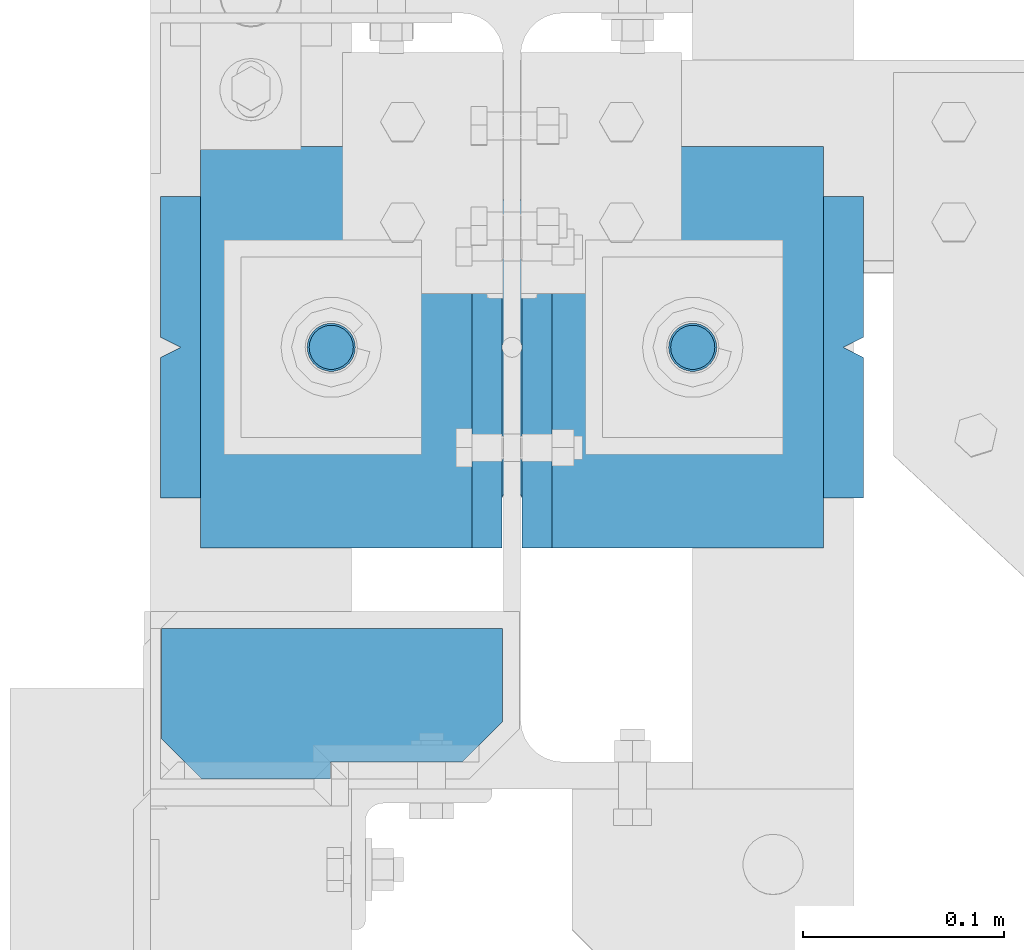
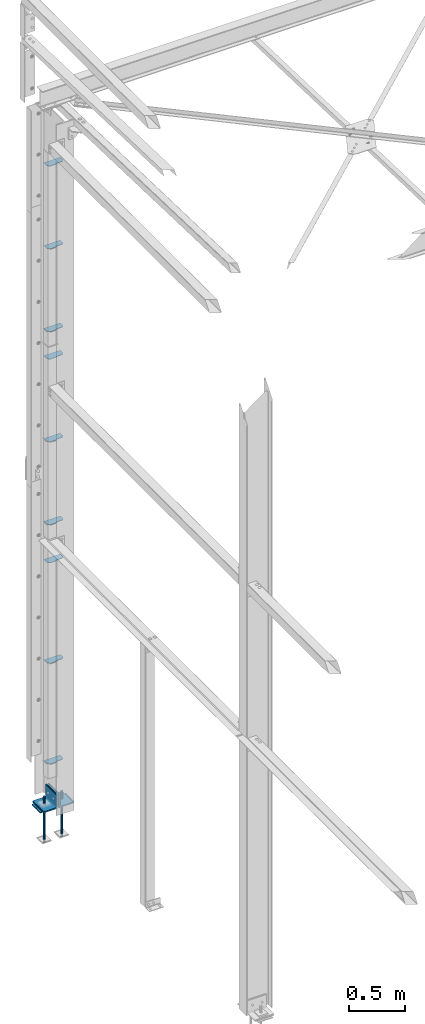
# One storey, part 79 of 496: 16 beams, 4 elements without a shape of their own.
"""IFC2X3 building model written with IfcOpenShell, lengths in millimetres."""

from ifc_helpers import new_model, si_unit, frame, origin_with_axes, origin_2d_with_axis, place, context, subcontext, project, spatial, polyline, rectangle, circle, l_section, outline, extrude, boolean, material, type_object, element, aggregate, save


model = new_model("IFC2X3")

# Units and contexts
model_context = context("Model", 3, precision=1e-05, world=origin_with_axes())
body_context = subcontext(model_context, "Body", "Model", "MODEL_VIEW")
ifc_project = project(units=[si_unit("LENGTHUNIT", "METRE", prefix="MILLI"), si_unit("AREAUNIT", "SQUARE_METRE"), si_unit("VOLUMEUNIT", "CUBIC_METRE"), si_unit("MASSUNIT", "GRAM", prefix="KILO"), si_unit("TIMEUNIT", "SECOND"), si_unit("PLANEANGLEUNIT", "RADIAN"), si_unit("SOLIDANGLEUNIT", "STERADIAN"), si_unit("THERMODYNAMICTEMPERATUREUNIT", "DEGREE_CELSIUS"), si_unit("LUMINOUSINTENSITYUNIT", "LUMEN")], contexts=[model_context])

# Site, building, storey
site_placement = place(None, origin_with_axes())
site = spatial("IfcSite", under=ifc_project, at=site_placement, CompositionType="ELEMENT")
building_placement = place(site_placement, origin_with_axes())
building = spatial("IfcBuilding", under=site, at=building_placement, Name="Undefined", CompositionType="ELEMENT")
storey_placement = place(building_placement, origin_with_axes())
storey = spatial("IfcBuildingStorey", under=building, at=storey_placement, Name="Undefined", CompositionType="ELEMENT", Elevation=0.0)

# Assembly, beams
assembly_1_placement = place(storey_placement, origin_with_axes())
assembly_1 = element("IfcElementAssembly", 1, at=assembly_1_placement, inside=storey, Name="PS24", AssemblyPlace="NOTDEFINED", PredefinedType="NOTDEFINED")
ifc_material = material(Name="Undefined/S235-E24")
beam_type_1 = type_object("IfcBeamType", Name="D24", PredefinedType="NOTDEFINED")
beam_1_placement = place(assembly_1_placement, frame((-90.0028495552906, 15109.9999996154, -100.0), z_axis=(0.0, 1.0, 0.0), x_axis=(0.0, 0.0, -1.0)))
beam_1 = element("IfcBeam", 2, at=beam_1_placement, type_object=beam_type_1, material=ifc_material, ObjectType="D24", context=body_context, shape_type="SweptSolid", body=[
    extrude(circle(Radius=12.0, at=origin_2d_with_axis()), frame((149.999995982835, 4.54747350886464e-12, 3.63797880709171e-12), z_axis=(-1.0, 0.0, 0.0), x_axis=(0.0, -1.0, 0.0)), (0.0, 0.0, 1.0), 150.0),
])
beam_2_placement = place(assembly_1_placement, frame((89.9971504447094, 15109.9999996154, -100.0), z_axis=(0.0, 1.0, 0.0), x_axis=(0.0, 0.0, -1.0)))
beam_2 = element("IfcBeam", 3, at=beam_2_placement, type_object=beam_type_1, material=ifc_material, ObjectType="D24", context=body_context, shape_type="SweptSolid", body=[
    extrude(circle(Radius=12.0, at=origin_2d_with_axis()), frame((149.999995982835, 4.54747350886464e-12, 3.63797880709171e-12), z_axis=(-1.0, 0.0, 0.0), x_axis=(0.0, -1.0, 0.0)), (0.0, 0.0, 1.0), 150.0),
])
beam_type_2 = type_object("IfcBeamType", Name="D22", PredefinedType="NOTDEFINED")
beam_3_placement = place(assembly_1_placement, frame((-90.0028495552906, 15109.9999996154, -250.0), z_axis=(0.0, 1.0, 0.0), x_axis=(0.0, 0.0, -1.0)))
beam_3 = element("IfcBeam", 4, at=beam_3_placement, type_object=beam_type_2, material=ifc_material, ObjectType="D22", context=body_context, shape_type="SweptSolid", body=[
    extrude(circle(Radius=11.0, at=origin_2d_with_axis()), frame((350.0, 0.0, 0.0), z_axis=(-1.0, 0.0, 0.0), x_axis=(0.0, -1.0, 0.0)), (0.0, 0.0, 1.0), 350.0),
])
beam_4_placement = place(assembly_1_placement, frame((89.9971504447094, 15109.9999996154, -250.0), z_axis=(0.0, 1.0, 0.0), x_axis=(0.0, 0.0, -1.0)))
beam_4 = element("IfcBeam", 5, at=beam_4_placement, type_object=beam_type_2, material=ifc_material, ObjectType="D22", context=body_context, shape_type="SweptSolid", body=[
    extrude(circle(Radius=11.0, at=origin_2d_with_axis()), frame((350.0, 0.0, 0.0), z_axis=(-1.0, 0.0, 0.0), x_axis=(0.0, -1.0, 0.0)), (0.0, 0.0, 1.0), 350.0),
])
beam_type_3 = type_object("IfcBeamType", PredefinedType="NOTDEFINED")
beam_5_placement = place(assembly_1_placement, frame((175.0, 15109.9999996154, -205.0), z_axis=(0.0, -1.0, 0.0), x_axis=(-1.0, 0.0, 0.0)))
beam_5 = element("IfcBeam", 6, at=beam_5_placement, type_object=beam_type_3, material=ifc_material, Name="PS24", context=body_context, shape_type="CSG", body=[
    boolean("DIFFERENCE", boolean("DIFFERENCE", boolean("DIFFERENCE", boolean("DIFFERENCE", extrude(rectangle(XDim=10.0, YDim=150.0, at=origin_2d_with_axis()), frame((350.0, 0.0, 0.0), z_axis=(-1.0, 0.0, 0.0), x_axis=(0.0, -1.0, 0.0)), (0.0, 0.0, 1.0), 350.0), extrude(outline(polyline([(0.0, 0.0), (11.1803398132297, 1.2732925824821e-11), (4.47213602066586, 8.94427204135718), (0.0, 0.0)])), frame((0.0, 7.5, -5.0), z_axis=(0.0, -1.0, 0.0), x_axis=(0.894427191199935, 0.0, 0.44721359509992)), (0.0, 0.0, 1.0), 15.0)), extrude(outline(polyline([(0.0, 0.0), (11.1803398132297, 1.2732925824821e-11), (4.47213602066586, 8.94427204135718), (0.0, 0.0)])), frame((180.0, 7.5, -75.0), z_axis=(0.0, -1.0, 0.0), x_axis=(-0.447213595099959, 0.0, 0.894427191199915)), (0.0, 0.0, 1.0), 15.0)), extrude(outline(polyline([(0.0, 0.0), (11.1803398132297, 1.2732925824821e-11), (6.70820379256475, 8.94427204134627), (0.0, 0.0)])), frame((340.0, 7.5, 0.0), z_axis=(0.0, -1.0, 0.0), x_axis=(0.894427191199935, 0.0, -0.44721359509992)), (0.0, 0.0, 1.0), 15.0)), extrude(outline(polyline([(0.0, 0.0), (11.1803398132297, 1.2732925824821e-11), (4.47213602066586, 8.94427204135718), (0.0, 0.0)])), frame((170.0, 7.5, 75.0), z_axis=(0.0, -1.0, 0.0), x_axis=(0.447213595099959, 0.0, -0.894427191199915)), (0.0, 0.0, 1.0), 15.0)),
])
aggregate(assembly_1, [beam_1, beam_3, beam_2, beam_4, beam_5])

assembly_2_placement = place(storey_placement, origin_with_axes())
assembly_2 = element("IfcElementAssembly", 7, at=assembly_2_placement, inside=storey, Name="POTEAU", AssemblyPlace="NOTDEFINED", PredefinedType="NOTDEFINED")
beam_type_4 = type_object("IfcBeamType", PredefinedType="NOTDEFINED")
beam_6_placement = place(assembly_2_placement, frame((-90.4999965190107, 14894.9999950373, 6035.00000055154), z_axis=(0.0, 0.0, 1.0), x_axis=(0.0, 1.0, 0.0)))
beam_6 = element("IfcBeam", 8, at=beam_6_placement, type_object=beam_type_4, material=ifc_material, context=body_context, shape_type="SweptSolid", body=[
    extrude(outline(polyline([(0.0, 0.0), (8.50000476837158, -7.37543359718984e-12), (8.50000476846641, -65.6999969482573), (28.5000047684953, -85.6999969482928), (75.0000076295182, -85.6999969483754), (75.0000076292763, 84.0000305174449), (20.0000001612298, 84.0000305175426), (1.22841738717662e-07, 64.0000305175781), (0.0, 0.0)])), frame((0.0, 0.0, -2.5), z_axis=(0.0, 0.0, 1.0), x_axis=(1.0, 0.0, 0.0)), (0.0, 0.0, 1.0), 5.0),
])
beam_7_placement = place(assembly_2_placement, frame((-90.4999965078626, 14895.0002723382, 3924.99998199652), z_axis=(0.0, 0.0, 1.0), x_axis=(0.0, 1.0, 0.0)))
beam_7 = element("IfcBeam", 9, at=beam_7_placement, type_object=beam_type_4, material=ifc_material, context=body_context, shape_type="SweptSolid", body=[
    extrude(outline(polyline([(0.0, 0.0), (8.50000476837158, -7.37543359718984e-12), (8.50000476846641, -65.6999969482573), (28.5000047684953, -85.6999969482928), (75.0000076295182, -85.6999969483754), (75.0000076292763, 84.0000305174449), (20.0000001612298, 84.0000305175426), (1.22841738717662e-07, 64.0000305175781), (0.0, 0.0)])), frame((0.0, 0.0, -2.5), z_axis=(0.0, 0.0, 1.0), x_axis=(1.0, 0.0, 0.0)), (0.0, 0.0, 1.0), 5.0),
])
beam_8_placement = place(assembly_2_placement, frame((-90.4999965136508, 14894.9999997548, 1505.00000012569), z_axis=(0.0, 0.0, 1.0), x_axis=(0.0, 1.0, 0.0)))
beam_8 = element("IfcBeam", 10, at=beam_8_placement, type_object=beam_type_4, material=ifc_material, context=body_context, shape_type="SweptSolid", body=[
    extrude(outline(polyline([(0.0, 0.0), (8.50000476837158, -7.37543359718984e-12), (8.50000476846641, -65.6999969482573), (28.5000047684953, -85.6999969482928), (75.0000076295182, -85.6999969483754), (75.0000076292763, 84.0000305174449), (20.0000001612298, 84.0000305175426), (1.22841738717662e-07, 64.0000305175781), (0.0, 0.0)])), frame((0.0, 0.0, -2.5), z_axis=(0.0, 0.0, 1.0), x_axis=(1.0, 0.0, 0.0)), (0.0, 0.0, 1.0), 5.0),
])
beam_9_placement = place(assembly_2_placement, frame((-90.4999965078027, 14894.9999980974, 2605.00000071572), z_axis=(0.0, 0.0, 1.0), x_axis=(0.0, 1.0, 0.0)))
beam_9 = element("IfcBeam", 11, at=beam_9_placement, type_object=beam_type_4, material=ifc_material, context=body_context, shape_type="SweptSolid", body=[
    extrude(outline(polyline([(0.0, 0.0), (8.50000476837158, -7.37543359718984e-12), (8.50000476846641, -65.6999969482573), (28.5000047684953, -85.6999969482928), (75.0000076295182, -85.6999969483754), (75.0000076292763, 84.0000305174449), (20.0000001612298, 84.0000305175426), (1.22841738717662e-07, 64.0000305175781), (0.0, 0.0)])), frame((0.0, 0.0, -2.5), z_axis=(0.0, 0.0, 1.0), x_axis=(1.0, 0.0, 0.0)), (0.0, 0.0, 1.0), 5.0),
])
beam_10_placement = place(assembly_2_placement, frame((-90.4999965023681, 14895.0000014121, 404.999999535647), z_axis=(0.0, 0.0, 1.0), x_axis=(0.0, 1.0, 0.0)))
beam_10 = element("IfcBeam", 12, at=beam_10_placement, type_object=beam_type_4, material=ifc_material, context=body_context, shape_type="SweptSolid", body=[
    extrude(outline(polyline([(0.0, 0.0), (8.50000476837158, -7.37543359718984e-12), (8.50000476846641, -65.6999969482573), (28.5000047684953, -85.6999969482928), (75.0000076295182, -85.6999969483754), (75.0000076292763, 84.0000305174449), (20.0000001612298, 84.0000305175426), (1.22841738717662e-07, 64.0000305175781), (0.0, 0.0)])), frame((0.0, 0.0, -2.5), z_axis=(0.0, 0.0, 1.0), x_axis=(1.0, 0.0, 0.0)), (0.0, 0.0, 1.0), 5.0),
])
beam_11_placement = place(assembly_2_placement, frame((-90.4999965131625, 14895.0000045366, 6939.99998843758), z_axis=(0.0, 0.0, 1.0), x_axis=(0.0, 1.0, 0.0)))
beam_11 = element("IfcBeam", 13, at=beam_11_placement, type_object=beam_type_4, material=ifc_material, context=body_context, shape_type="SweptSolid", body=[
    extrude(outline(polyline([(0.0, 0.0), (8.50000476837158, -7.37543359718984e-12), (8.50000476846641, -65.6999969482573), (28.5000047684953, -85.6999969482928), (75.0000076295182, -85.6999969483754), (75.0000076292763, 84.0000305174449), (20.0000001612298, 84.0000305175426), (1.22841738717662e-07, 64.0000305175781), (0.0, 0.0)])), frame((0.0, 0.0, -2.5), z_axis=(0.0, 0.0, 1.0), x_axis=(1.0, 0.0, 0.0)), (0.0, 0.0, 1.0), 5.0),
])
beam_12_placement = place(assembly_2_placement, frame((-90.4999965117919, 14894.9999207421, 5130.00000007699), z_axis=(0.0, 0.0, 1.0), x_axis=(0.0, 1.0, 0.0)))
beam_12 = element("IfcBeam", 14, at=beam_12_placement, type_object=beam_type_4, material=ifc_material, context=body_context, shape_type="SweptSolid", body=[
    extrude(outline(polyline([(0.0, 0.0), (8.50000476837158, -7.37543359718984e-12), (8.50000476846641, -65.6999969482573), (28.5000047684953, -85.6999969482928), (75.0000076295182, -85.6999969483754), (75.0000076292763, 84.0000305174449), (20.0000001612298, 84.0000305175426), (1.22841738717662e-07, 64.0000305175781), (0.0, 0.0)])), frame((0.0, 0.0, -2.5), z_axis=(0.0, 0.0, 1.0), x_axis=(1.0, 0.0, 0.0)), (0.0, 0.0, 1.0), 5.0),
])
beam_13_placement = place(assembly_2_placement, frame((-90.4999965020145, 14895.00054377, 4829.99996391821), z_axis=(0.0, 0.0, 1.0), x_axis=(0.0, 1.0, 0.0)))
beam_13 = element("IfcBeam", 15, at=beam_13_placement, type_object=beam_type_4, material=ifc_material, context=body_context, shape_type="SweptSolid", body=[
    extrude(outline(polyline([(0.0, 0.0), (8.50000476837158, -7.37543359718984e-12), (8.50000476846641, -65.6999969482573), (28.5000047684953, -85.6999969482928), (75.0000076295182, -85.6999969483754), (75.0000076292763, 84.0000305174449), (20.0000001612298, 84.0000305175426), (1.22841738717662e-07, 64.0000305175781), (0.0, 0.0)])), frame((0.0, 0.0, -2.5), z_axis=(0.0, 0.0, 1.0), x_axis=(1.0, 0.0, 0.0)), (0.0, 0.0, 1.0), 5.0),
])
beam_14_placement = place(assembly_2_placement, frame((-90.4999964966154, 14895.0000009063, 3020.00000007662), z_axis=(0.0, 0.0, 1.0), x_axis=(0.0, 1.0, 0.0)))
beam_14 = element("IfcBeam", 16, at=beam_14_placement, type_object=beam_type_4, material=ifc_material, context=body_context, shape_type="SweptSolid", body=[
    extrude(outline(polyline([(0.0, 0.0), (8.50000476837158, -7.37543359718984e-12), (8.50000476846641, -65.6999969482573), (28.5000047684953, -85.6999969482928), (75.0000076295182, -85.6999969483754), (75.0000076292763, 84.0000305174449), (20.0000001612298, 84.0000305175426), (1.22841738717662e-07, 64.0000305175781), (0.0, 0.0)])), frame((0.0, 0.0, -2.5), z_axis=(0.0, 0.0, 1.0), x_axis=(1.0, 0.0, 0.0)), (0.0, 0.0, 1.0), 5.0),
])
aggregate(assembly_2, [beam_6, beam_7, beam_8, beam_9, beam_10, beam_11, beam_12, beam_13, beam_14])

# Assembly, beam
assembly_3_placement = place(storey_placement, origin_with_axes())
assembly_3 = element("IfcElementAssembly", 17, at=assembly_3_placement, inside=storey, AssemblyPlace="NOTDEFINED", PredefinedType="NOTDEFINED")
beam_type_5 = type_object("IfcBeamType", PredefinedType="NOTDEFINED")
beam_15_placement = place(assembly_3_placement, frame((-80.0028489018421, 15210.0000024004, -124.999999899389), z_axis=(0.0, 0.0, 1.0), x_axis=(0.0, -1.0, 0.0)))
beam_15 = element("IfcBeam", 18, at=beam_15_placement, type_object=beam_type_5, material=ifc_material, context=body_context, shape_type="SweptSolid", body=[
    extrude(l_section(Depth=150.0, Width=150.0, Thickness=15.0, FilletRadius=16.0, EdgeRadius=8.0, at=origin_2d_with_axis()), frame((200.0, 0.0, 0.0), z_axis=(-1.0, 0.0, 0.0), x_axis=(0.0, -1.0, 0.0)), (0.0, 0.0, 1.0), 200.0),
])
aggregate(assembly_3, [beam_15])

assembly_4_placement = place(storey_placement, origin_with_axes())
assembly_4 = element("IfcElementAssembly", 19, at=assembly_4_placement, inside=storey, AssemblyPlace="NOTDEFINED", PredefinedType="NOTDEFINED")
beam_16_placement = place(assembly_4_placement, frame((79.9971510983967, 15010.0000024003, -124.999999899406), z_axis=(0.0, 0.0, 1.0), x_axis=(0.0, 1.0, 0.0)))
beam_16 = element("IfcBeam", 20, at=beam_16_placement, type_object=beam_type_5, material=ifc_material, context=body_context, shape_type="SweptSolid", body=[
    extrude(l_section(Depth=150.0, Width=150.0, Thickness=15.0, FilletRadius=16.0, EdgeRadius=8.0, at=origin_2d_with_axis()), frame((200.0, 0.0, 0.0), z_axis=(-1.0, 0.0, 0.0), x_axis=(0.0, -1.0, 0.0)), (0.0, 0.0, 1.0), 200.0),
])
aggregate(assembly_4, [beam_16])

save(model, "model.ifc")
